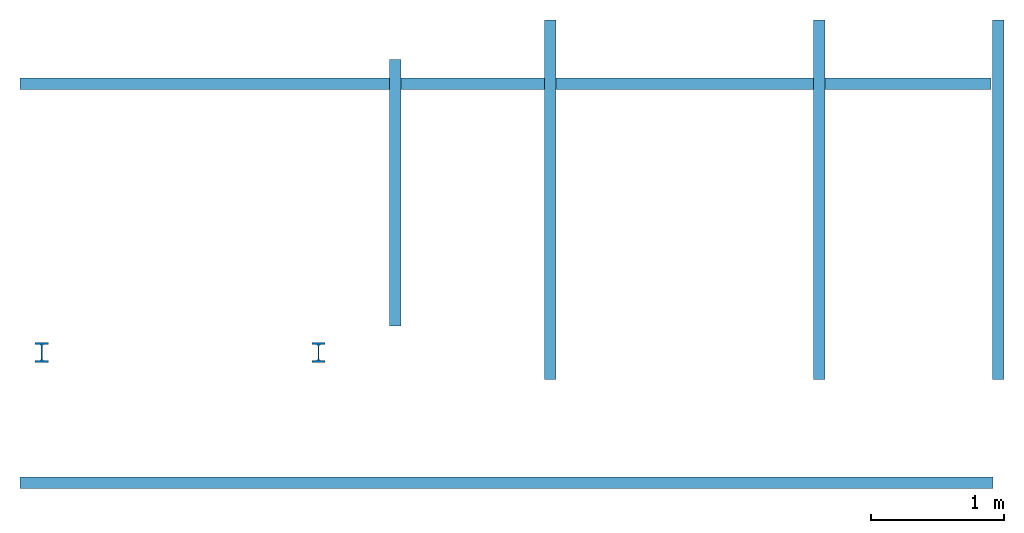
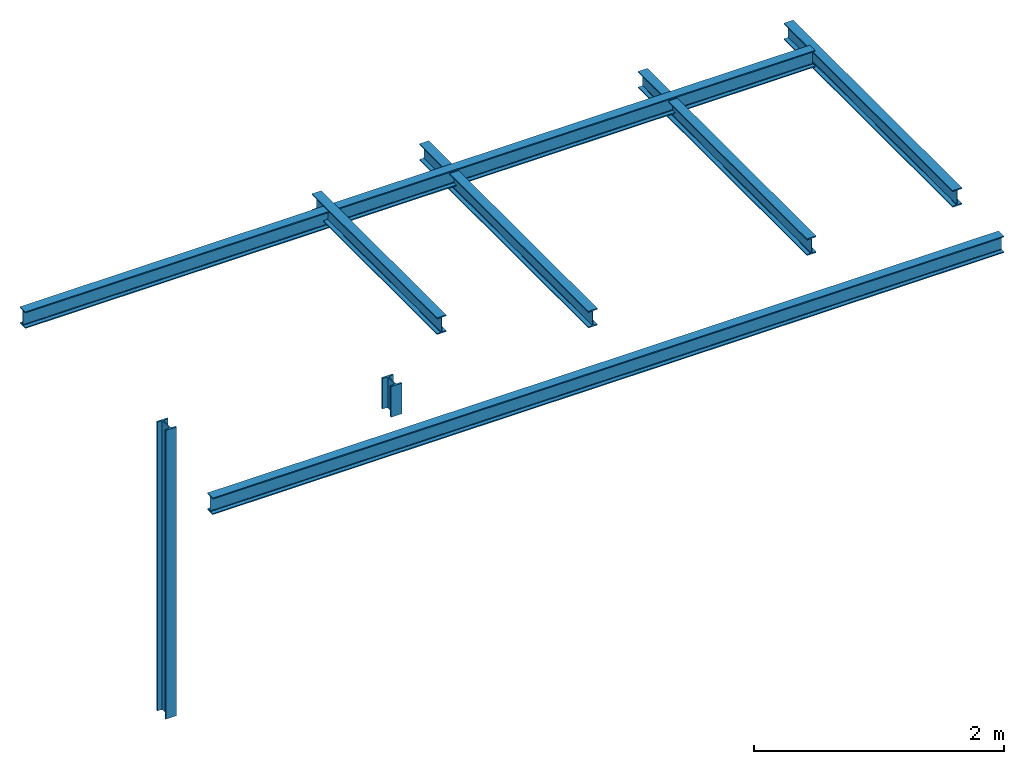
# One storey: 6 beams, 2 columns.
"""IFC2X3 building model written with IfcOpenShell, lengths in millimetres."""

import ifcopenshell
import ifcopenshell.guid

model = None  # the IFC model being written
_history = None  # IfcOwnerHistory: only IFC2X3 demands one
_inside = {}  # id of a spatial element -> (the spatial element, [elements in it])
_under = {}  # id of a project, library or spatial element -> (it, [spatial elements below it])
_declared = {}  # id of a project -> (the project, [libraries it declares])
_typed = {}  # id of a type object -> (the type object, [elements of that type])
_made_of = {}  # id of a material, layer set ... -> (it, [elements and type objects made of it])


def new_model(schema):
    """Start an empty IFC model of exactly this schema.

    Asked for "IFC4X3", IfcOpenShell would pick the latest addendum, in which some entities
    have other attributes; the version numbers below select the first issue.
    IFC2X3 requires an IfcOwnerHistory on every rooted entity: one is made here for all.
    """
    global model, _history
    if schema == "IFC4X3":
        model = ifcopenshell.file(schema_version=(4, 3, 0, 0))
    else:
        model = ifcopenshell.file(schema=schema)
    _inside.clear()
    _under.clear()
    _declared.clear()
    _typed.clear()
    _made_of.clear()
    _history = None
    if model.schema == "IFC2X3":
        org = make("IfcOrganization", Name="unknown")
        user = make(
            "IfcPersonAndOrganization",
            ThePerson=make("IfcPerson", FamilyName="unknown"),
            TheOrganization=org,
        )
        app = make(
            "IfcApplication",
            ApplicationDeveloper=org,
            Version="unknown",
            ApplicationFullName="unknown",
            ApplicationIdentifier="unknown",
        )
        _history = make(
            "IfcOwnerHistory",
            OwningUser=user,
            OwningApplication=app,
            ChangeAction="ADDED",
            CreationDate=0,
        )
    return model


def make(cls, **values):
    """One entity of the class cls with the attributes given. An attribute that is None is left unset."""
    return model.create_entity(
        cls, **{name: value for name, value in values.items() if value is not None}
    )


def entity(cls, *values):
    """Any entity or typed value of the class cls, its attributes in the order of the schema. None: left unset."""
    e = model.create_entity(cls)
    for i, value in enumerate(values):
        if value is not None:
            e[i] = value
    return e


def rooted(cls, **values):
    """An entity with a GlobalId (a new one), such as an element, a storey or a relation."""
    return make(cls, GlobalId=ifcopenshell.guid.new(), OwnerHistory=_history, **values)


def si_unit(unit_type, name, prefix=None):
    """IfcSIUnit, for example si_unit("LENGTHUNIT", "METRE", prefix="MILLI")."""
    return make("IfcSIUnit", UnitType=unit_type, Prefix=prefix, Name=name)


def converted_unit(unit_type, name, factor, base, dimensions=None, offset=None):
    """IfcConversionBasedUnit, such as the inch: factor (a typed value) times the base unit."""
    return make(
        "IfcConversionBasedUnit"
        if offset is None
        else "IfcConversionBasedUnitWithOffset",
        ConversionOffset=offset,
        Dimensions=None
        if dimensions is None
        else entity("IfcDimensionalExponents", *dimensions),
        UnitType=unit_type,
        Name=name,
        ConversionFactor=make(
            "IfcMeasureWithUnit", ValueComponent=factor, UnitComponent=base
        ),
    )


def derived_unit(unit_type, elements):
    """IfcDerivedUnit: a product of units, each with its exponent."""
    return make(
        "IfcDerivedUnit",
        Elements=[
            make("IfcDerivedUnitElement", Unit=unit, Exponent=power)
            for unit, power in elements
        ],
        UnitType=unit_type,
    )


def assignment(units):
    """IfcUnitAssignment: the units of a project."""
    return None if units is None else make("IfcUnitAssignment", Units=units)


def point(xyz):
    """IfcCartesianPoint."""
    return None if xyz is None else make("IfcCartesianPoint", Coordinates=xyz)


def direction(xyz):
    """IfcDirection."""
    return None if xyz is None else make("IfcDirection", DirectionRatios=xyz)


def frame(location, z_axis=None, x_axis=None):
    """IfcAxis2Placement3D, a coordinate frame: its origin and axes. An axis left out is left unset."""
    return make(
        "IfcAxis2Placement3D",
        Location=point(location),
        Axis=direction(z_axis),
        RefDirection=direction(x_axis),
    )


def frame_2d(location, x_axis=None):
    """IfcAxis2Placement2D, a coordinate frame in the plane: its origin and x axis."""
    return make(
        "IfcAxis2Placement2D", Location=point(location), RefDirection=direction(x_axis)
    )


def origin():
    """The frame at (0, 0, 0) with its axes left unset."""
    return frame((0.0, 0.0, 0.0))


def place(relative_to, where):
    """IfcLocalPlacement: puts the frame where relative to a parent placement (None: the world)."""
    return make(
        "IfcLocalPlacement", PlacementRelTo=relative_to, RelativePlacement=where
    )


def context(
    kind, dimensions, precision=None, world=None, true_north=None, identifier=None
):
    """IfcGeometricRepresentationContext, for example the 3D "Model" context."""
    return make(
        "IfcGeometricRepresentationContext",
        ContextIdentifier=identifier,
        ContextType=kind,
        CoordinateSpaceDimension=dimensions,
        Precision=precision,
        WorldCoordinateSystem=world,
        TrueNorth=true_north,
    )


def subcontext(parent, identifier, kind, view, scale=None):
    """IfcGeometricRepresentationSubContext, for example "Body" below "Model"."""
    return make(
        "IfcGeometricRepresentationSubContext",
        ContextIdentifier=identifier,
        ContextType=kind,
        ParentContext=parent,
        TargetScale=scale,
        TargetView=view,
    )


def project(units=None, contexts=None):
    """IfcProject with its units and contexts."""
    return rooted(
        "IfcProject",
        Name="project",
        RepresentationContexts=contexts,
        UnitsInContext=assignment(units),
    )


def spatial(cls, under=None, at=None, **own):
    """A site, building, storey or space (cls), placed at a placement, below another one or the project."""
    s = rooted(cls, ObjectPlacement=at, **own)
    if under is not None:
        _under.setdefault(under.id(), (under, []))[1].append(s)
    return s


def profile(cls, at=None, kind="AREA", **sizes):
    """A parametric profile (cls). Its sizes go by their IFC names, for example OverallWidth=200.0."""
    return make(cls, ProfileType=kind, Position=at, **sizes)


def i_section(**sizes):
    """IfcIShapeProfileDef."""
    return profile("IfcIShapeProfileDef", **sizes)


def extrude(swept, where, along, depth):
    """IfcExtrudedAreaSolid: the profile swept, set in the frame where, extruded along a direction by depth."""
    return make(
        "IfcExtrudedAreaSolid",
        SweptArea=swept,
        Position=where,
        ExtrudedDirection=direction(along),
        Depth=depth,
    )


def shape(context_of_items, identifier, shape_type, items):
    """IfcShapeRepresentation: the items that make up one representation, for example the "Body"."""
    return make(
        "IfcShapeRepresentation",
        ContextOfItems=context_of_items,
        RepresentationIdentifier=identifier,
        RepresentationType=shape_type,
        Items=items,
    )


def source(mapping_origin, context_of_items, identifier, shape_type, items):
    """IfcRepresentationMap: a shape defined once, which mapped items show again and again."""
    return make(
        "IfcRepresentationMap",
        MappingOrigin=mapping_origin,
        MappedRepresentation=shape(context_of_items, identifier, shape_type, items),
    )


def transform(
    local_origin,
    x_axis=None,
    y_axis=None,
    z_axis=None,
    scale=None,
    scale2=None,
    scale3=None,
    uniform=True,
):
    """IfcCartesianTransformationOperator3D, or its non-uniform kind. x_axis, y_axis, z_axis: its Axis1, 2, 3."""
    if uniform:
        return make(
            "IfcCartesianTransformationOperator3D",
            Axis1=direction(x_axis),
            Axis2=direction(y_axis),
            LocalOrigin=point(local_origin),
            Scale=scale,
            Axis3=direction(z_axis),
        )
    return make(
        "IfcCartesianTransformationOperator3DnonUniform",
        Axis1=direction(x_axis),
        Axis2=direction(y_axis),
        LocalOrigin=point(local_origin),
        Scale=scale,
        Axis3=direction(z_axis),
        Scale2=scale2,
        Scale3=scale3,
    )


def mapped(mapping_source, mapping_target):
    """IfcMappedItem: shows the shape of a source again, moved by a transform."""
    return make(
        "IfcMappedItem", MappingSource=mapping_source, MappingTarget=mapping_target
    )


def material(Name=None, Category=None):
    """IfcMaterial."""
    return make("IfcMaterial", Name=Name, Category=Category)


def made_of(thing, what):
    """Note that an element or type object is made of a material, layer set ...; save() writes the relation."""
    if what is not None:
        _made_of.setdefault(what.id(), (what, []))[1].append(thing)
    return thing


def type_object(cls, material=None, **own):
    """A type object (cls), such as IfcWallType, which elements share."""
    return made_of(rooted(cls, **own), material)


def type_shapes(of_type, sources):
    """Give a type object the sources (RepresentationMaps) that its elements show as mapped items."""
    of_type.RepresentationMaps = sources


def element(
    cls,
    number,
    at=None,
    inside=None,
    cuts=None,
    type_object=None,
    material=None,
    context=None,
    identifier="Body",
    shape_type=None,
    held_by="IfcProductDefinitionShape",
    body=None,
    shapes=None,
    **own,
):
    """One element of the class cls, such as IfcWall. Its Tag is "e" and its number.

    at: its placement. inside: the storey or other place that contains it. cuts: it is an
    opening in that element (IfcRelVoidsElement). A single representation is given by context,
    identifier, shape_type and body (its items); several are given by shapes. held_by: the class
    of the entity that holds the representations. save() writes the other relations.
    """
    e = rooted(cls, Tag="e%d" % number, ObjectPlacement=at, **own)
    if body is not None:
        shapes = [shape(context, identifier, shape_type, body)]
    if shapes is not None:
        e.Representation = make(held_by, Representations=shapes)
    if inside is not None:
        _inside.setdefault(inside.id(), (inside, []))[1].append(e)
    if cuts is not None:
        rooted(
            "IfcRelVoidsElement", RelatingBuildingElement=cuts, RelatedOpeningElement=e
        )
    if type_object is not None:
        _typed.setdefault(type_object.id(), (type_object, []))[1].append(e)
    return made_of(e, material)


def aggregate(whole, parts):
    """IfcRelAggregates: a whole, such as a stair, and the parts it consists of."""
    return rooted("IfcRelAggregates", RelatingObject=whole, RelatedObjects=parts)


def save(model, path):
    """Write the relations noted so far, then the file.

    IfcRelAggregates (storeys below a building ...), IfcRelContainedInSpatialStructure (elements
    in a storey), IfcRelDefinesByType, IfcRelAssociatesMaterial and IfcRelDeclares: one each for
    every whole, place, type object, material and project.
    """
    for whole, parts in _under.values():
        aggregate(whole, parts)
    for where, things in _inside.values():
        rooted(
            "IfcRelContainedInSpatialStructure",
            RelatedElements=things,
            RelatingStructure=where,
        )
    for kind, things in _typed.values():
        rooted("IfcRelDefinesByType", RelatedObjects=things, RelatingType=kind)
    for what, things in _made_of.values():
        rooted("IfcRelAssociatesMaterial", RelatedObjects=things, RelatingMaterial=what)
    for by, libraries in _declared.values():
        rooted("IfcRelDeclares", RelatingContext=by, RelatedDefinitions=libraries)
    model.write(path)


model = new_model("IFC2X3")

# Units and contexts
model_context = context("Model", 3, precision=0.01, world=origin(), true_north=direction((6.12303176911189e-17, 1.0)))
body_context = subcontext(model_context, "Body", "Model", "MODEL_VIEW")
ifc_project = project(units=[si_unit("LENGTHUNIT", "METRE", prefix="MILLI"), si_unit("AREAUNIT", "SQUARE_METRE"), si_unit("VOLUMEUNIT", "CUBIC_METRE"), converted_unit("PLANEANGLEUNIT", "DEGREE", entity("IfcRatioMeasure", 0.0174532925199433), si_unit("PLANEANGLEUNIT", "RADIAN"), dimensions=[0, 0, 0, 0, 0, 0, 0]), si_unit("MASSUNIT", "GRAM", prefix="KILO"), si_unit("TIMEUNIT", "SECOND"), si_unit("FREQUENCYUNIT", "HERTZ"), si_unit("THERMODYNAMICTEMPERATUREUNIT", "DEGREE_CELSIUS"), derived_unit("THERMALTRANSMITTANCEUNIT", [(si_unit("MASSUNIT", "GRAM", prefix="KILO"), 1), (si_unit("THERMODYNAMICTEMPERATUREUNIT", "KELVIN"), -1), (si_unit("TIMEUNIT", "SECOND"), -3)]), derived_unit("VOLUMETRICFLOWRATEUNIT", [(si_unit("LENGTHUNIT", "METRE"), 3), (si_unit("TIMEUNIT", "SECOND"), -1)]), si_unit("ELECTRICCURRENTUNIT", "AMPERE"), si_unit("ELECTRICVOLTAGEUNIT", "VOLT"), si_unit("POWERUNIT", "WATT"), si_unit("FORCEUNIT", "NEWTON", prefix="KILO"), si_unit("ILLUMINANCEUNIT", "LUX"), si_unit("LUMINOUSFLUXUNIT", "LUMEN"), si_unit("LUMINOUSINTENSITYUNIT", "CANDELA"), derived_unit("USERDEFINED", [(si_unit("MASSUNIT", "GRAM", prefix="KILO"), -1), (si_unit("LENGTHUNIT", "METRE"), -2), (si_unit("TIMEUNIT", "SECOND"), 3), (si_unit("LUMINOUSFLUXUNIT", "LUMEN"), 1)]), derived_unit("LINEARVELOCITYUNIT", [(si_unit("LENGTHUNIT", "METRE"), 1), (si_unit("TIMEUNIT", "SECOND"), -1)]), si_unit("PRESSUREUNIT", "PASCAL"), derived_unit("USERDEFINED", [(si_unit("LENGTHUNIT", "METRE"), -2), (si_unit("MASSUNIT", "GRAM", prefix="KILO"), 1), (si_unit("TIMEUNIT", "SECOND"), -2)])], contexts=[model_context])

# Site, building, storey
site_placement = place(None, origin())
site = spatial("IfcSite", under=ifc_project, at=site_placement, CompositionType="ELEMENT")
building_placement = place(site_placement, origin())
building = spatial("IfcBuilding", under=site, at=building_placement, CompositionType="ELEMENT")
storey_placement = place(building_placement, origin())
storey = spatial("IfcBuildingStorey", under=building, at=storey_placement, CompositionType="ELEMENT", Elevation=0.0)

# Columns
ifc_material = material(Name="ocel 43-275")
column_type_1 = type_object("IfcColumnType", Name="UC305x305x97", PredefinedType="COLUMN", material=ifc_material)
shared_shape_1 = source(origin(), body_context, "Body", "SweptSolid", [
    extrude(i_section(OverallWidth=100.0, OverallDepth=150.0, WebThickness=9.9, FlangeThickness=15.4, FilletRadius=15.2, at=frame_2d((7.105427357601e-15, 1.06581410364015e-14), x_axis=(0.0, 1.0))), frame((0.0, 0.0, -20.0), z_axis=(0.0, 0.0, 1.0), x_axis=(0.0, -1.0, 0.0)), (0.0, 0.0, 1.0), 2820.0),
])
type_shapes(column_type_1, [shared_shape_1])
column_1_placement = place(storey_placement, frame((-11713.255860133, -106.674624441704, 0.0)))
element("IfcColumn", 1, at=column_1_placement, inside=storey, type_object=column_type_1, material=ifc_material, ObjectType="UC305x305x97", context=body_context, shape_type="MappedRepresentation", body=[
    mapped(shared_shape_1, transform((0.0, 0.0, 0.0), scale=1.0)),
])
column_type_2 = type_object("IfcColumnType", Name="UC305x305x97", PredefinedType="COLUMN", material=ifc_material)
shared_shape_2 = source(origin(), body_context, "Body", "SweptSolid", [
    extrude(i_section(OverallWidth=100.0, OverallDepth=150.0, WebThickness=9.9, FlangeThickness=15.4, FilletRadius=15.2, at=frame_2d((7.105427357601e-15, 1.06581410364015e-14), x_axis=(0.0, 1.0))), frame((0.0, 0.0, 2200.0), z_axis=(0.0, 0.0, 1.0), x_axis=(0.0, -1.0, 0.0)), (0.0, 0.0, 1.0), 300.0),
])
type_shapes(column_type_2, [shared_shape_2])
column_2_placement = place(storey_placement, frame((-9633.25586013304, -106.674624441711, 0.0)))
element("IfcColumn", 2, at=column_2_placement, inside=storey, type_object=column_type_2, material=ifc_material, ObjectType="UC305x305x97", context=body_context, shape_type="MappedRepresentation", body=[
    mapped(shared_shape_2, transform((0.0, 0.0, 0.0), scale=1.0)),
])

# Beams
beam_1_placement = place(storey_placement, frame((-9056.25586013304, 2093.32537555828, 0.0), z_axis=(0.0, 0.0, 1.0), x_axis=(0.0, -1.0, 0.0)))
element("IfcBeam", 3, at=beam_1_placement, inside=storey, material=ifc_material, context=body_context, shape_type="SweptSolid", body=[
    extrude(i_section(OverallWidth=85.0000000000002, OverallDepth=163.4, WebThickness=5.99999999999972, FlangeThickness=10.2000000000009, FilletRadius=8.90000000000008, at=frame_2d((0.0, 1.08357767203415e-12), x_axis=(0.0, 1.0))), frame((0.0, 0.0, 2718.29999999999), z_axis=(1.0, 0.0, 0.0), x_axis=(0.0, 0.0, -1.0)), (0.0, 0.0, 1.0), 2000.0),
])
beam_2_placement = place(storey_placement, frame((-4566.75586013303, -1084.67462444171, 0.0), z_axis=(0.0, 0.0, 1.0), x_axis=(-1.0, 0.0, 0.0)))
element("IfcBeam", 4, at=beam_2_placement, inside=storey, material=ifc_material, context=body_context, shape_type="SweptSolid", body=[
    extrude(i_section(OverallWidth=85.0000000000002, OverallDepth=163.4, WebThickness=5.99999999999999, FlangeThickness=10.2000000000009, FilletRadius=8.90000000000028, at=frame_2d((0.0, 1.35003119794419e-13), x_axis=(0.0, 1.0))), frame((0.0, 0.0, 2671.29999999999), z_axis=(1.0, 0.0, 0.0), x_axis=(0.0, 0.0, -1.0)), (0.0, 0.0, 1.0), 7309.0),
])
beam_3_placement = place(storey_placement, frame((-4525.35452428204, 1913.32537555829, 0.0), z_axis=(0.0, 0.0, 1.0), x_axis=(-1.0, 0.0, 0.0)))
element("IfcBeam", 5, at=beam_3_placement, inside=storey, material=ifc_material, context=body_context, shape_type="SweptSolid", body=[
    extrude(i_section(OverallWidth=85.0000000000002, OverallDepth=163.4, WebThickness=6.00000000000026, FlangeThickness=10.2000000000009, FilletRadius=8.89999999999998, at=frame_2d((0.0, -2.70006239588838e-13), x_axis=(0.0, 1.0))), frame((55.2006679254965, 0.0, 2671.29999999999), z_axis=(1.0, 0.0, 0.0), x_axis=(0.0, 0.0, -1.0)), (0.0, 0.0, 1.0), 7295.2),
])
beam_4_placement = place(storey_placement, frame((-5871.23689076013, -308.544384868714, 0.0), z_axis=(0.0, 0.0, 1.0), x_axis=(0.0, 1.0, 0.0)))
element("IfcBeam", 6, at=beam_4_placement, inside=storey, material=ifc_material, context=body_context, shape_type="SweptSolid", body=[
    extrude(i_section(OverallWidth=85.0000000000002, OverallDepth=163.4, WebThickness=5.99999999999972, FlangeThickness=10.2000000000009, FilletRadius=8.90000000000008, at=frame_2d((5.40012479177676e-13, 0.0), x_axis=(0.0, 1.0))), frame((0.0, 0.0, 2618.29999999999), z_axis=(1.0, 0.0, 0.0), x_axis=(0.0, 0.0, -1.0)), (0.0, 0.0, 1.0), 2700.0),
])
beam_5_placement = place(storey_placement, frame((-7891.23689076013, -308.544384868707, 0.0), z_axis=(0.0, 0.0, 1.0), x_axis=(0.0, 1.0, 0.0)))
element("IfcBeam", 7, at=beam_5_placement, inside=storey, material=ifc_material, context=body_context, shape_type="SweptSolid", body=[
    extrude(i_section(OverallWidth=85.0000000000002, OverallDepth=163.4, WebThickness=5.99999999999972, FlangeThickness=10.2000000000009, FilletRadius=8.90000000000008, at=frame_2d((8.10018718766514e-13, 1.08357767203415e-12), x_axis=(0.0, 1.0))), frame((0.0, 0.0, 2618.29999999999), z_axis=(1.0, 0.0, 0.0), x_axis=(0.0, 0.0, -1.0)), (0.0, 0.0, 1.0), 2700.0),
])
beam_6_placement = place(storey_placement, frame((-4525.35452428205, -308.544384868718, 0.0), z_axis=(0.0, 0.0, 1.0), x_axis=(0.0, 1.0, 0.0)))
element("IfcBeam", 8, at=beam_6_placement, inside=storey, material=ifc_material, context=body_context, shape_type="SweptSolid", body=[
    extrude(i_section(OverallWidth=85.0000000000002, OverallDepth=163.4, WebThickness=6.00000000000026, FlangeThickness=10.2000000000009, FilletRadius=8.90000000000043, at=frame_2d((5.40012479177676e-13, 8.10018718766514e-13), x_axis=(0.0, 1.0))), frame((0.0, 0.0, 2618.29999999999), z_axis=(1.0, 0.0, 0.0), x_axis=(0.0, 0.0, -1.0)), (0.0, 0.0, 1.0), 2700.0),
])

save(model, "model.ifc")
